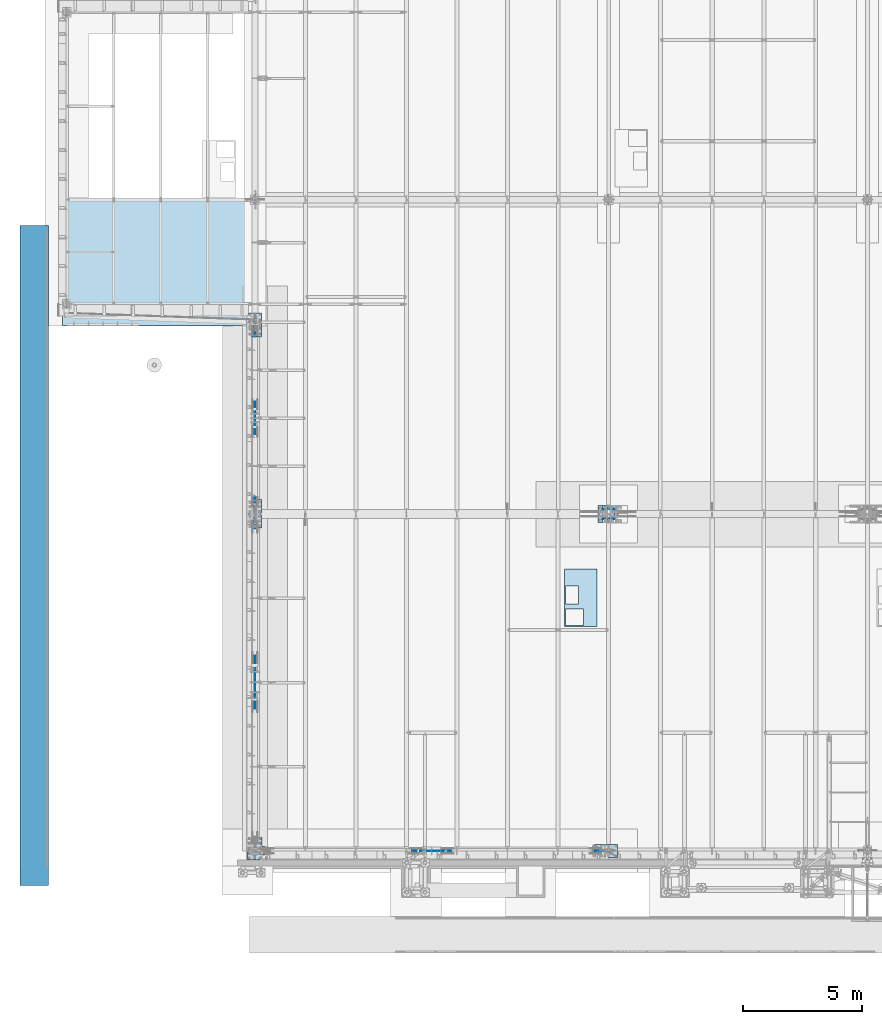
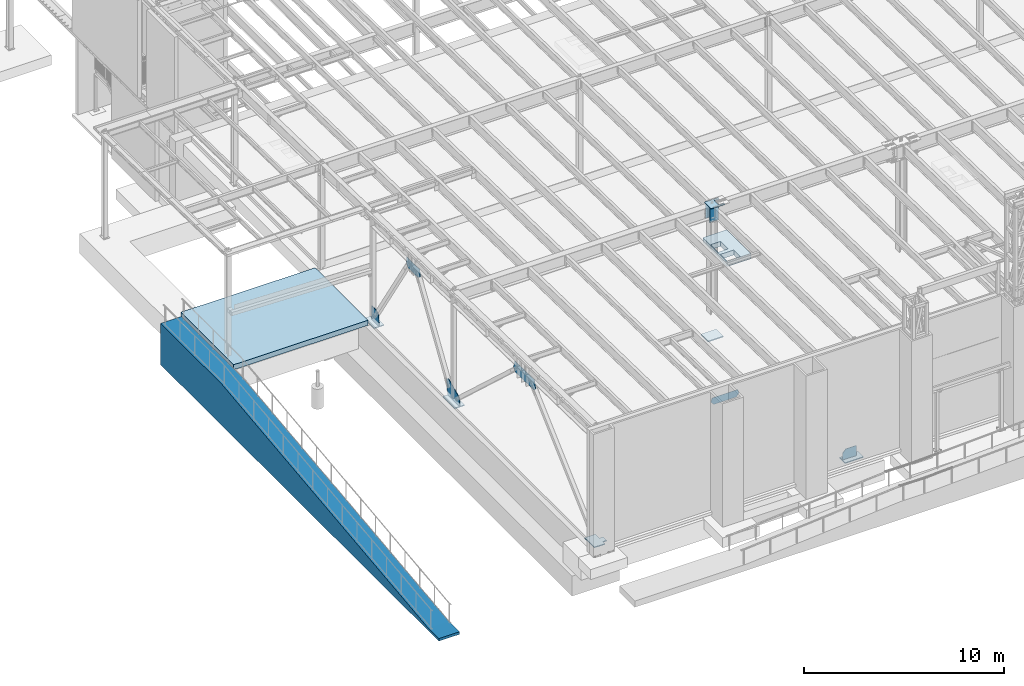
# One storey, part 1408 of 1763: 15 plates, 2 slabs, 11 elements without a shape of their own.
"""IFC2X3 building model written with IfcOpenShell, lengths in millimetres."""

from ifc_helpers import new_model, si_unit, frame, origin_with_axes, place, context, subcontext, project, spatial, faceted_brep, material, type_object, element, aggregate, save


model = new_model("IFC2X3")

# Units and contexts
model_context = context("Model", 3, precision=1e-05, world=origin_with_axes())
body_context = subcontext(model_context, "Body", "Model", "MODEL_VIEW")
ifc_project = project(units=[si_unit("LENGTHUNIT", "METRE", prefix="MILLI"), si_unit("AREAUNIT", "SQUARE_METRE"), si_unit("VOLUMEUNIT", "CUBIC_METRE"), si_unit("MASSUNIT", "GRAM", prefix="KILO"), si_unit("TIMEUNIT", "SECOND"), si_unit("PLANEANGLEUNIT", "RADIAN"), si_unit("SOLIDANGLEUNIT", "STERADIAN"), si_unit("THERMODYNAMICTEMPERATUREUNIT", "DEGREE_CELSIUS"), si_unit("LUMINOUSINTENSITYUNIT", "LUMEN")], contexts=[model_context])

# Site, building, storey
site_placement = place(None, origin_with_axes())
site = spatial("IfcSite", under=ifc_project, at=site_placement, CompositionType="ELEMENT")
building_placement = place(site_placement, origin_with_axes())
building = spatial("IfcBuilding", under=site, at=building_placement, Name="Undefined", CompositionType="ELEMENT")
storey_placement = place(building_placement, origin_with_axes())
storey = spatial("IfcBuildingStorey", under=building, at=storey_placement, Name="Undefined", CompositionType="ELEMENT", Elevation=0.0)

# Assembly, plate
assembly_1_placement = place(storey_placement, origin_with_axes())
assembly_1 = element("IfcElementAssembly", 1, at=assembly_1_placement, inside=storey, Name="B-BOX", AssemblyPlace="NOTDEFINED", PredefinedType="RIGID_FRAME")
ifc_material_1 = material(Name="STEEL/A36")
plate_type_1 = type_object("IfcPlateType", PredefinedType="NOTDEFINED")
plate_1_placement = place(assembly_1_placement, frame((-74349.7924659729, -4264.56192860603, 11747.5), z_axis=(0.0, 1.0, 0.0), x_axis=(1.0, 0.0, 0.0)))
plate_1 = element("IfcPlate", 2, at=plate_1_placement, type_object=plate_type_1, material=ifc_material_1, Name="B-BOX", context=body_context, shape_type="Brep", body=[
    faceted_brep([(596.899999999994, -152.4, 1691.12592269852), (596.899999999994, 152.4, 1691.12592269852), (596.899999999994, 152.4, 939.803901214145), (596.899999999994, -152.4, 939.803901214145), (44.4499877929629, 152.4, 939.803901214145), (44.4499877929629, -152.4, 939.803901214145), (44.4499877929629, 152.4, 1695.45388175919), (44.4499877929629, -152.4, 1695.45388175919), (596.899999999994, 152.4, 1695.45388175919), (596.899999999994, -152.4, 1695.45388175919), (1377.94995117188, -152.4, 0.0), (0.0, -152.4, 0.0), (0.0, 152.4, 0.0), (1377.94995117188, 152.4, 0.0), (1377.94995117188, -152.4, 2422.52490234375), (1377.94995117188, 152.4, 2422.52490234375), (0.0, -152.4, 2422.52490234375), (0.0, 152.4, 2422.52490234375), (44.4499999999971, -152.4, 44.4499999999971), (44.4500244140654, -152.4, 723.903857421872), (800.091015625003, -152.4, 723.903857421872), (800.091015625003, -152.4, 44.4499999999971), (44.4499999999971, 152.4, 44.4499999999971), (44.4500244140654, 152.4, 723.903857421872), (800.091015625003, 152.4, 44.4499999999971), (800.091015625003, 152.4, 723.903857421872)], [[[0, 1, 2, 3]], [[3, 2, 4, 5]], [[5, 4, 6, 7]], [[7, 6, 8, 9]], [[9, 8, 1, 0]], [[10, 11, 12, 13]], [[14, 10, 13, 15]], [[16, 14, 15, 17]], [[11, 16, 17, 12]], [[10, 14, 16, 11], [3, 5, 7, 9, 0], [18, 19, 20, 21]], [[18, 22, 23, 19]], [[21, 24, 22, 18]], [[20, 25, 24, 21]], [[19, 23, 25, 20]], [[15, 13, 12, 17], [4, 2, 1, 8, 6], [22, 24, 25, 23]]]),
])
aggregate(assembly_1, [plate_1])

# Assembly, slab
assembly_2_placement = place(storey_placement, origin_with_axes())
assembly_2 = element("IfcElementAssembly", 3, at=assembly_2_placement, inside=storey, Name="SLAB", AssemblyPlace="NOTDEFINED", PredefinedType="REINFORCEMENT_UNIT")
ifc_material_2 = material(Name="CONCRETE/3000")
slab_type_1 = type_object("IfcSlabType", PredefinedType="NOTDEFINED")
slab_1_placement = place(assembly_2_placement, frame((-95478.0372736984, 13690.6, 5181.6), z_axis=(1.0, 0.0, 0.0), x_axis=(0.0, -1.0, 0.0)))
slab_1 = element("IfcSlab", 4, at=slab_1_placement, type_object=slab_type_1, material=ifc_material_2, Name="SLAB", PredefinedType="FLOOR", context=body_context, shape_type="Brep", body=[
    faceted_brep([(0.0, -152.4, 0.0), (-0.0001983642578125, -152.4, 177.800003051758), (-0.0001983642578125, 152.4, 177.800003051758), (0.0, 152.4, 0.0), (-0.0001983642578125, -152.4, 7747.0), (-0.0001983642578125, 152.4, 7747.0), (5283.2001953125, -152.4, 7747.0), (5283.2001953125, 152.4, 7747.0), (5283.2001953125, -152.4, 0.0), (5283.2001953125, 152.4, 0.0)], [[[0, 1, 2, 3]], [[1, 4, 5, 2]], [[4, 6, 7, 5]], [[6, 8, 9, 7]], [[8, 0, 3, 9]], [[5, 7, 9, 3, 2]], [[8, 6, 4, 1, 0]]]),
])
aggregate(assembly_2, [slab_1])

assembly_3_placement = place(storey_placement, origin_with_axes())
assembly_3 = element("IfcElementAssembly", 5, at=assembly_3_placement, inside=storey, Name="CONC_RAMP", AssemblyPlace="NOTDEFINED", PredefinedType="REINFORCEMENT_UNIT")
slab_type_2 = type_object("IfcSlabType", PredefinedType="NOTDEFINED")
slab_2_placement = place(assembly_3_placement, frame((-96667.2527017878, -15170.3625831113, 3562.35), z_axis=(0.0, 1.0, 0.0), x_axis=(0.0, 0.0, -1.0)))
slab_2 = element("IfcSlab", 6, at=slab_2_placement, type_object=slab_type_2, material=ifc_material_2, Name="CONC_RAMP", PredefinedType="FLOOR", context=body_context, shape_type="Brep", body=[
    faceted_brep([(0.0, -596.899999999994, 0.0), (0.000638678902760148, -596.899999999994, 1066.86853027344), (0.000638678902760148, 596.899999999994, 1066.86853027344), (0.0, 596.899999999994, 0.0), (-2367.88159179688, -596.899999999994, 21690.880859375), (-2367.88159179688, 596.899999999994, 21690.880859375), (-2367.88159179688, -596.899999999994, 27786.880859375), (-2367.88159179688, 596.899999999994, 27786.880859375), (152.400115966797, -596.899999999994, 27786.880859375), (152.400115966797, 596.899999999994, 27786.880859375), (152.399993896484, -596.899999999994, 0.0), (152.399993896484, 596.899999999994, 0.0)], [[[0, 1, 2, 3]], [[1, 4, 5, 2]], [[4, 6, 7, 5]], [[6, 8, 9, 7]], [[8, 10, 11, 9]], [[10, 0, 3, 11]], [[5, 7, 9, 11, 3, 2]], [[10, 8, 6, 4, 1, 0]]]),
])
aggregate(assembly_3, [slab_2])

# Assembly, plates
assembly_4_placement = place(storey_placement, origin_with_axes())
assembly_4 = element("IfcElementAssembly", 7, at=assembly_4_placement, inside=storey, Name="COLUMN", AssemblyPlace="NOTDEFINED", PredefinedType="RIGID_FRAME")
ifc_material_3 = material(Name="STEEL/A572-50")
plate_type_2 = type_object("IfcPlateType", PredefinedType="NOTDEFINED")
plate_2_placement = place(assembly_4_placement, frame((-72741.8622734155, 796.924983214496, 11894.1086715128), z_axis=(1.0, 0.0, 0.0), x_axis=(0.0, -1.0, 0.0)))
plate_2 = element("IfcPlate", 8, at=plate_2_placement, type_object=plate_type_2, material=ifc_material_3, Name="PLATE", context=body_context, shape_type="Brep", body=[
    faceted_brep([(120.649988524181, -14.2875000006989, 787.41003417968), (120.649988524193, -14.2875000004697, 527.049974308022), (120.649988524193, 14.2874999995311, 527.049974365225), (120.649988524181, 14.2874999993019, 787.410034179702), (122.583448369369, -14.2875000004606, 517.329815271936), (122.583448369369, 14.2874999995402, 517.329815329133), (128.089476170325, -14.2875000004515, 509.089462335629), (128.089476170325, 14.2874999995474, 509.089462392825), (136.329829106632, -14.2875000004478, 503.583434534674), (136.329829106632, 14.2874999995529, 503.58343459187), (146.049988142723, -14.287500000446, 501.649974689499), (146.049988142723, 14.2874999995547, 501.649974746695), (533.399982802148, -14.287500000446, 501.649974689499), (533.399982802148, 14.2874999995547, 501.649974746695), (543.120141838239, -14.2875000004478, 503.583434534674), (543.120141838239, 14.2874999995529, 503.58343459187), (551.360494774547, -14.2875000004515, 509.089462335629), (551.360494774547, 14.2874999995474, 509.089462392825), (556.866522575503, -14.2875000004606, 517.329815271936), (556.866522575503, 14.2874999995402, 517.329815329133), (558.799982420678, -14.2875000004697, 527.049974308029), (558.799982420678, 14.2874999995311, 527.049974365225), (558.799982420678, -14.2875000007007, 787.410014972702), (558.799982420678, 14.2874999993019, 787.410034179702), (0.0, -14.2875000000058, 0.0), (-3.66389258488198e-07, -14.2875000006989, 787.41003417968), (-3.66389258488198e-07, 14.2874999993019, 787.410034179702), (0.0, 14.2875000000058, 0.0), (679.449951171875, -14.2875000000004, -2.18278728425503e-11), (679.449951171875, 14.2875000000004, 0.0), (679.449951171875, -14.2875000006989, 787.41003417968), (679.449951171875, 14.2874999993019, 787.410034179702)], [[[0, 1, 2, 3]], [[4, 5, 2, 1]], [[6, 7, 5, 4]], [[8, 9, 7, 6]], [[10, 11, 9, 8]], [[12, 13, 11, 10]], [[14, 15, 13, 12]], [[16, 17, 15, 14]], [[18, 19, 17, 16]], [[20, 21, 19, 18]], [[22, 23, 21, 20]], [[24, 25, 26, 27]], [[28, 24, 27, 29]], [[30, 28, 29, 31]], [[18, 16, 14, 12, 10, 8, 6, 4, 1, 0, 25, 24, 28, 30, 22, 20]], [[26, 25, 0, 3]], [[31, 29, 27, 26, 3, 2, 5, 7, 9, 11, 13, 15, 17, 19, 21, 23]], [[30, 31, 23, 22]]]),
])
plate_type_3 = type_object("IfcPlateType", PredefinedType="NOTDEFINED")
plate_3_placement = place(assembly_4_placement, frame((-72741.8622736972, 247.6500183114, 11879.8211718204), z_axis=(1.0, 0.0, 0.0), x_axis=(0.0, 0.0, -1.0)))
plate_3 = element("IfcPlate", 9, at=plate_3_placement, type_object=plate_type_3, material=ifc_material_3, Name="PLATE", context=body_context, shape_type="Brep", body=[
    faceted_brep([(0.0, -9.52500000000146, 0.0), (6.91016430209856e-06, -9.52499999999998, 501.64999389647), (6.91017339704558e-06, 9.52500000000001, 501.64999389647), (0.0, 9.52500000000146, 0.0), (888.999999999838, -9.52499999998997, 501.649963380791), (888.999999999847, 9.52500000000995, 501.649963380791), (888.999999999996, -9.52499999999003, 2.43016984313726e-09), (889.000000000007, 9.52500000000998, 2.43016984313726e-09)], [[[0, 1, 2, 3]], [[1, 4, 5, 2]], [[4, 6, 7, 5]], [[6, 0, 3, 7]], [[5, 7, 3, 2]], [[6, 4, 1, 0]]]),
])
plate_4_placement = place(assembly_4_placement, frame((-72741.8622736972, 666.750000000849, 11879.8211716828), z_axis=(1.0, 0.0, 0.0), x_axis=(0.0, 0.0, -1.0)))
plate_4 = element("IfcPlate", 10, at=plate_4_placement, type_object=plate_type_3, material=ifc_material_3, Name="PLATE", context=body_context, shape_type="Brep", body=[
    faceted_brep([(0.0, -9.52500000000146, 0.0), (6.91016430209856e-06, -9.52499999999998, 501.64999389647), (6.91017339704558e-06, 9.52500000000001, 501.64999389647), (0.0, 9.52500000000146, 0.0), (888.999999999838, -9.52499999998997, 501.649963380791), (888.999999999847, 9.52500000000995, 501.649963380791), (888.999999999996, -9.52499999999003, 2.43016984313726e-09), (889.000000000007, 9.52500000000998, 2.43016984313726e-09)], [[[0, 1, 2, 3]], [[1, 4, 5, 2]], [[4, 6, 7, 5]], [[6, 0, 3, 7]], [[5, 7, 3, 2]], [[6, 4, 1, 0]]]),
])

# Assembly, plate
assembly_5_placement = place(storey_placement, origin_with_axes())
assembly_5 = element("IfcElementAssembly", 11, at=assembly_5_placement, inside=storey, Name="BEAM", AssemblyPlace="NOTDEFINED", PredefinedType="RIGID_FRAME")
ifc_material_4 = material(Name="STEEL/A572-GR.50")
plate_type_4 = type_object("IfcPlateType", PredefinedType="NOTDEFINED")
plate_5_placement = place(assembly_5_placement, frame((-79194.6094366964, -13716.0, 11544.2999999932), z_axis=(0.0, 0.0, -1.0), x_axis=(-1.0, 0.0, 0.0)))
plate_5 = element("IfcPlate", 12, at=plate_5_placement, type_object=plate_type_4, material=ifc_material_4, Name="PLATE", context=body_context, shape_type="Brep", body=[
    faceted_brep([(0.0, -9.52500000000146, 0.0), (-76.0641937255859, -9.52499999999964, 236.643829345703), (-76.0641937255859, 9.52499999999964, 236.643829345703), (0.0, 9.52500000000146, 0.0), (94.4907150268555, -9.52499999999964, 424.864501953125), (94.4907150268555, 9.52499999999964, 424.864501953125), (1382.76501464844, -9.52499999999964, 424.864501953125), (1382.76501464844, 9.52499999999964, 424.864501953125), (1553.31982421875, -9.52499999999964, 236.643829345703), (1553.31982421875, 9.52499999999964, 236.643829345703), (1477.25561523438, -9.52499999999964, -1.81898940354586e-12), (1477.25561523438, 9.52499999999964, -1.81898940354586e-12)], [[[0, 1, 2, 3]], [[1, 4, 5, 2]], [[4, 6, 7, 5]], [[6, 8, 9, 7]], [[8, 10, 11, 9]], [[10, 0, 3, 11]], [[5, 7, 9, 11, 3, 2]], [[10, 8, 6, 4, 1, 0]]]),
])
aggregate(assembly_5, [plate_5])

assembly_6_placement = place(storey_placement, origin_with_axes())
assembly_6 = element("IfcElementAssembly", 13, at=assembly_6_placement, inside=storey, Name="BEAM", AssemblyPlace="NOTDEFINED", PredefinedType="RIGID_FRAME")
plate_type_5 = type_object("IfcPlateType", PredefinedType="NOTDEFINED")
plate_6_placement = place(assembly_6_placement, frame((-87375.4372736983, -7585.22061009422, 11288.9583483192), z_axis=(0.0, -0.0209013569953167, -0.999781542776098), x_axis=(0.0, 0.999781542776098, -0.0209013569953182)))
plate_6 = element("IfcPlate", 14, at=plate_6_placement, type_object=plate_type_5, material=ifc_material_4, Name="PLATE", context=body_context, shape_type="Brep", body=[
    faceted_brep([(0.0, -9.52500000000146, 0.0), (-136.694915771626, -9.52499999999418, 472.521728515956), (-136.694915771626, 9.52499999999418, 472.521728515956), (0.0, 9.52500000000146, 0.0), (39.3188209531481, -9.52499999999418, 655.647827148976), (39.3188209531481, 9.52499999999418, 655.647827148976), (1917.05676269489, -9.52499999999418, 655.647827149631), (1917.05676269489, 9.52499999999418, 655.647827149631), (2096.78930664025, -9.52499999999418, 452.28390503039), (2096.78930664025, 9.52499999999418, 452.28390503039), (1945.19543457011, -9.52499999999418, 7.14862835593522e-10), (1945.19543457011, 9.52499999999418, 7.14862835593522e-10)], [[[0, 1, 2, 3]], [[1, 4, 5, 2]], [[4, 6, 7, 5]], [[6, 8, 9, 7]], [[8, 10, 11, 9]], [[10, 0, 3, 11]], [[5, 7, 9, 11, 3, 2]], [[10, 8, 6, 4, 1, 0]]]),
])
aggregate(assembly_6, [plate_6])

assembly_7_placement = place(storey_placement, origin_with_axes())
assembly_7 = element("IfcElementAssembly", 15, at=assembly_7_placement, inside=storey, Name="BEAM", AssemblyPlace="NOTDEFINED", PredefinedType="RIGID_FRAME")
plate_type_6 = type_object("IfcPlateType", PredefinedType="NOTDEFINED")
plate_7_placement = place(assembly_7_placement, frame((-87375.4372736983, 3838.78613045941, 11062.831716303), z_axis=(0.0, -0.0209013569953167, -0.999781542776098), x_axis=(0.0, 0.999781542776098, -0.0209013569953182)))
plate_7 = element("IfcPlate", 16, at=plate_7_placement, type_object=plate_type_6, material=ifc_material_4, Name="PLATE", context=body_context, shape_type="Brep", body=[
    faceted_brep([(0.0, -9.52500000000146, 0.0), (-11.2983131408114, -9.52499999999418, 449.296844482775), (-11.2983131408114, 9.52499999999418, 449.296844482775), (0.0, 9.52500000000146, 0.0), (205.410003662161, -9.52499999999418, 581.786499023972), (205.410003662161, 9.52499999999418, 581.786499023972), (1139.69604492183, -9.52499999999418, 581.786499024296), (1139.69604492183, 9.52499999999418, 581.786499024296), (1354.90454101554, -9.52499999999418, 437.522247315272), (1354.90454101554, 9.52499999999418, 437.522247315272), (1325.56982421861, -9.52499999999418, 4.85670170746744e-10), (1325.56982421861, 9.52499999999418, 4.85670170746744e-10)], [[[0, 1, 2, 3]], [[1, 4, 5, 2]], [[4, 6, 7, 5]], [[6, 8, 9, 7]], [[8, 10, 11, 9]], [[10, 0, 3, 11]], [[5, 7, 9, 11, 3, 2]], [[10, 8, 6, 4, 1, 0]]]),
])
aggregate(assembly_7, [plate_7])

assembly_8_placement = place(storey_placement, origin_with_axes())
assembly_8 = element("IfcElementAssembly", 17, at=assembly_8_placement, inside=storey, Name="COLUMN", AssemblyPlace="NOTDEFINED", PredefinedType="RIGID_FRAME")
plate_type_7 = type_object("IfcPlateType", PredefinedType="NOTDEFINED")
plate_8_placement = place(assembly_8_placement, frame((-87375.4372736983, 1066.8, 5130.8), z_axis=(0.0, -0.991612808566339, 0.129244101943478), x_axis=(0.0, 0.129244101943478, 0.991612808566339)))
plate_8 = element("IfcPlate", 18, at=plate_8_placement, type_object=plate_type_7, material=ifc_material_4, Name="PLATE", context=body_context, shape_type="Brep", body=[
    faceted_brep([(229.238098144348, -12.6999999999971, 1260.55603027286), (229.23809814411, 12.6999999999971, 1260.55603027333), (-154.291604653979, 12.6999999999971, 1183.78742105754), (-154.291604653979, -12.6999999999971, 1183.78742105754), (906.96081542943, -12.6999999999971, -7.62838681112044e-11), (0.0, -12.6999999999971, -1.81898940354586e-12), (0.0, 12.6999999999971, -1.81898940354586e-12), (906.96081542943, 12.6999999999971, -7.62838681112044e-11), (1015.15777587855, -12.6999999999971, 229.802993774422), (1015.15777587855, 12.6999999999971, 229.802993774422), (436.685729980029, -12.6999999999971, 1113.99047851554), (436.685729980029, 12.6999999999971, 1113.99047851554)], [[[0, 1, 2, 3]], [[4, 5, 6, 7]], [[8, 4, 7, 9]], [[10, 8, 9, 11]], [[5, 4, 8, 10, 0, 3]], [[6, 5, 3, 2]], [[11, 9, 7, 6, 2, 1]], [[10, 11, 1, 0]]]),
])

assembly_9_placement = place(storey_placement, origin_with_axes())
assembly_9 = element("IfcElementAssembly", 19, at=assembly_9_placement, inside=storey, Name="COLUMN", AssemblyPlace="NOTDEFINED", PredefinedType="RIGID_FRAME")
plate_type_8 = type_object("IfcPlateType", PredefinedType="NOTDEFINED")
plate_9_placement = place(assembly_9_placement, frame((-72364.0372736984, -13716.0, 5742.44052185967), z_axis=(-1.0, 0.0, 0.0), x_axis=(0.0, 0.0, -1.0)))
plate_9 = element("IfcPlate", 20, at=plate_9_placement, type_object=plate_type_8, material=ifc_material_4, Name="PLATE", context=body_context, shape_type="Brep", body=[
    faceted_brep([(0.0, -12.6999999999971, -1.81898940354586e-12), (0.0, -12.7000000000007, 612.857543945312), (0.0, 12.7000000000007, 612.857543945312), (0.0, 12.6999999999971, -1.81898940354586e-12), (188.220672607422, -12.7000000000007, 783.412475585938), (188.220672607422, 12.7000000000007, 783.412475585938), (611.640502929688, -12.7000000000007, 812.799987792969), (611.640502929688, 12.7000000000007, 812.799987792969), (611.640502929688, -12.7000000000007, 0.0), (611.640502929688, 12.7000000000007, 0.0)], [[[0, 1, 2, 3]], [[1, 4, 5, 2]], [[4, 6, 7, 5]], [[6, 8, 9, 7]], [[8, 0, 3, 9]], [[5, 7, 9, 3, 2]], [[8, 6, 4, 1, 0]]]),
])

assembly_10_placement = place(storey_placement, origin_with_axes())
assembly_10 = element("IfcElementAssembly", 21, at=assembly_10_placement, inside=storey, Name="COLUMN", AssemblyPlace="NOTDEFINED", PredefinedType="RIGID_FRAME")
plate_type_9 = type_object("IfcPlateType", PredefinedType="NOTDEFINED")
plate_10_placement = place(assembly_10_placement, frame((-87375.4372736983, 8661.3999999988, 5955.83767449709), z_axis=(0.0, -1.0, 0.0), x_axis=(0.0, 0.0, -1.0)))
plate_10 = element("IfcPlate", 22, at=plate_10_placement, type_object=plate_type_9, material=ifc_material_4, Name="PLATE", context=body_context, shape_type="Brep", body=[
    faceted_brep([(0.0, -12.6999999999971, -1.81898940354586e-12), (0.0, -12.6999999999971, 504.593170166016), (0.0, 12.6999999999971, 504.593170166016), (0.0, 12.6999999999971, -1.81898940354586e-12), (136.990188598633, -12.6999999999971, 718.484924316406), (136.990188598633, 12.6999999999971, 718.484924316406), (825.037658691406, -12.6999999999971, 736.599975585938), (825.037658691406, 12.6999999999971, 736.599975585938), (825.037658691406, -12.6999999999971, 0.0), (825.037658691406, 12.6999999999971, 0.0)], [[[0, 1, 2, 3]], [[1, 4, 5, 2]], [[4, 6, 7, 5]], [[6, 8, 9, 7]], [[8, 0, 3, 9]], [[5, 7, 9, 3, 2]], [[8, 6, 4, 1, 0]]]),
])

# Plate
plate_type_10 = type_object("IfcPlateType", PredefinedType="NOTDEFINED")
plate_11_placement = place(assembly_4_placement, frame((-72935.5372736972, 101.600000000843, 3879.85), z_axis=(0.0, 1.0, 0.0), x_axis=(1.0, 0.0, 0.0)))
plate_11 = element("IfcPlate", 23, at=plate_11_placement, type_object=plate_type_10, material=ifc_material_4, Name="PLATE", context=body_context, shape_type="Brep", body=[
    faceted_brep([(-4.54747350886464e-13, -31.7499999999964, 0.0), (0.0, -31.75, 711.200012207031), (0.0, 31.75, 711.200012207031), (-5.91171556152403e-12, 31.7499999999891, 0.0), (889.0, -31.75, 711.200012207031), (889.0, 31.75, 711.200012207031), (889.0, -31.75, 0.0), (889.0, 31.75, 0.0)], [[[0, 1, 2, 3]], [[1, 4, 5, 2]], [[4, 6, 7, 5]], [[6, 0, 3, 7]], [[5, 7, 3, 2]], [[6, 4, 1, 0]]]),
])

aggregate(assembly_4, [plate_2, plate_3, plate_4, plate_11])

plate_type_11 = type_object("IfcPlateType", PredefinedType="NOTDEFINED")
plate_12_placement = place(assembly_8_placement, frame((-87654.8372736983, 1066.8, 5105.4), z_axis=(1.0, 0.0, 0.0), x_axis=(0.0, -1.0, 0.0)))
plate_12 = element("IfcPlate", 24, at=plate_12_placement, type_object=plate_type_11, material=ifc_material_4, Name="PLATE", context=body_context, shape_type="Brep", body=[
    faceted_brep([(0.0, -25.4000000000015, 0.0), (0.0, -25.3999999999996, 558.799987792969), (0.0, 25.3999999999996, 558.799987792969), (0.0, 25.4000000000015, 0.0), (1193.80004882812, -25.3999999999996, 558.799987792969), (1193.80004882812, 25.3999999999996, 558.799987792969), (1193.80004882812, -25.3999999999996, 0.0), (1193.80004882812, 25.3999999999996, 0.0)], [[[0, 1, 2, 3]], [[1, 4, 5, 2]], [[4, 6, 7, 5]], [[6, 0, 3, 7]], [[5, 7, 3, 2]], [[6, 4, 1, 0]]]),
])

aggregate(assembly_8, [plate_8, plate_12])

plate_13_placement = place(assembly_9_placement, frame((-73176.8372736983, -13436.6, 5105.4), z_axis=(1.0, 0.0, 0.0), x_axis=(0.0, -1.0, 0.0)))
plate_13 = element("IfcPlate", 25, at=plate_13_placement, type_object=plate_type_11, material=ifc_material_4, Name="PLATE", context=body_context, shape_type="Brep", body=[
    faceted_brep([(0.0, -25.4000000000015, 0.0), (0.0, -25.3999999999996, 1066.80004882812), (0.0, 25.3999999999996, 1066.80004882812), (0.0, 25.4000000000015, 0.0), (558.799987792969, -25.3999999999996, 1066.80004882812), (558.799987792969, 25.3999999999996, 1066.80004882812), (558.799987792969, -25.3999999999996, 0.0), (558.799987792969, 25.3999999999996, 0.0)], [[[0, 1, 2, 3]], [[1, 4, 5, 2]], [[4, 6, 7, 5]], [[6, 0, 3, 7]], [[5, 7, 3, 2]], [[6, 4, 1, 0]]]),
])

aggregate(assembly_9, [plate_9, plate_13])

plate_14_placement = place(assembly_10_placement, frame((-87654.8372736983, 8915.40000000001, 5105.40000000001), z_axis=(1.0, 0.0, 0.0), x_axis=(0.0, -1.0, 0.0)))
plate_14 = element("IfcPlate", 26, at=plate_14_placement, type_object=plate_type_11, material=ifc_material_4, Name="PLATE", context=body_context, shape_type="Brep", body=[
    faceted_brep([(0.0, -25.4000000000015, 0.0), (0.0, -25.3999999999996, 558.799987792969), (0.0, 25.3999999999996, 558.799987792969), (0.0, 25.4000000000015, 0.0), (990.599975585938, -25.3999999999996, 558.799987792969), (990.599975585938, 25.3999999999996, 558.799987792969), (990.599975585938, -25.3999999999996, 0.0), (990.599975585938, 25.3999999999996, 0.0)], [[[0, 1, 2, 3]], [[1, 4, 5, 2]], [[4, 6, 7, 5]], [[6, 0, 3, 7]], [[5, 7, 3, 2]], [[6, 4, 1, 0]]]),
])

aggregate(assembly_10, [plate_10, plate_14])

# Assembly, plate
assembly_11_placement = place(storey_placement, origin_with_axes())
assembly_11 = element("IfcElementAssembly", 27, at=assembly_11_placement, inside=storey, Name="COLUMN", AssemblyPlace="NOTDEFINED", PredefinedType="RIGID_FRAME")
plate_type_12 = type_object("IfcPlateType", PredefinedType="NOTDEFINED")
plate_15_placement = place(assembly_11_placement, frame((-87680.2372736984, -13131.8, 5105.40000000001), z_axis=(1.0, 0.0, 0.0), x_axis=(0.0, -1.0, 0.0)))
plate_15 = element("IfcPlate", 28, at=plate_15_placement, type_object=plate_type_12, material=ifc_material_4, Name="PLATE", context=body_context, shape_type="Brep", body=[
    faceted_brep([(0.0, -25.4000000000015, 0.0), (0.0, -25.3999999999996, 609.599975585938), (0.0, 25.3999999999996, 609.599975585938), (0.0, 25.4000000000015, 0.0), (406.399993896484, -25.3999999999996, 609.599975585938), (406.399993896484, 25.3999999999996, 609.599975585938), (406.399993896484, -25.3999999999996, 838.200012207031), (406.399993896484, 25.3999999999996, 838.200012207031), (762.0, -25.3999999999996, 838.200012207031), (762.0, 25.3999999999996, 838.200012207031), (762.0, -25.3999999999996, 609.599975585938), (762.0, 25.3999999999996, 609.599975585938), (965.200012207031, -25.3999999999996, 609.599975585938), (965.200012207031, 25.3999999999996, 609.599975585938), (965.200012207031, -25.3999999999996, 0.0), (965.200012207031, 25.3999999999996, 0.0)], [[[0, 1, 2, 3]], [[1, 4, 5, 2]], [[4, 6, 7, 5]], [[6, 8, 9, 7]], [[8, 10, 11, 9]], [[10, 12, 13, 11]], [[12, 14, 15, 13]], [[14, 0, 3, 15]], [[5, 7, 9, 11, 13, 15, 3, 2]], [[14, 12, 10, 8, 6, 4, 1, 0]]]),
])
aggregate(assembly_11, [plate_15])

save(model, "model.ifc")
